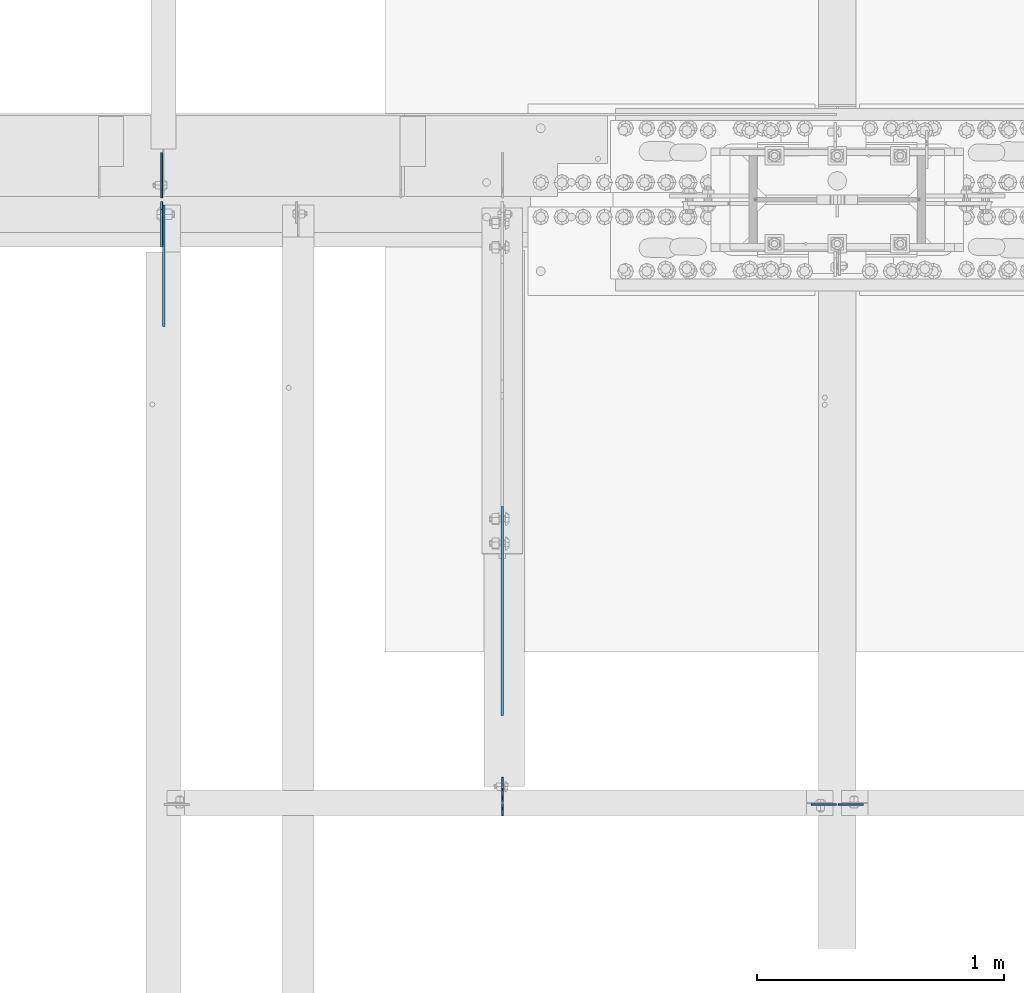
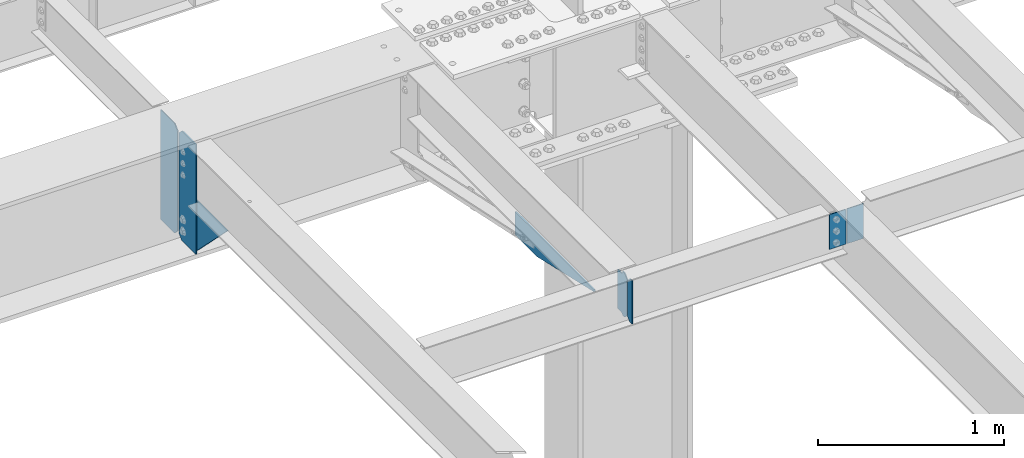
# One storey, part 1615 of 1763: 8 plates, 5 elements without a shape of their own.
"""IFC2X3 building model written with IfcOpenShell, lengths in millimetres."""

from ifc_helpers import new_model, si_unit, frame, origin_with_axes, place, context, subcontext, project, spatial, faceted_brep, material, type_object, element, aggregate, save


model = new_model("IFC2X3")

# Units and contexts
model_context = context("Model", 3, precision=1e-05, world=origin_with_axes())
body_context = subcontext(model_context, "Body", "Model", "MODEL_VIEW")
ifc_project = project(units=[si_unit("LENGTHUNIT", "METRE", prefix="MILLI"), si_unit("AREAUNIT", "SQUARE_METRE"), si_unit("VOLUMEUNIT", "CUBIC_METRE"), si_unit("MASSUNIT", "GRAM", prefix="KILO"), si_unit("TIMEUNIT", "SECOND"), si_unit("PLANEANGLEUNIT", "RADIAN"), si_unit("SOLIDANGLEUNIT", "STERADIAN"), si_unit("THERMODYNAMICTEMPERATUREUNIT", "DEGREE_CELSIUS"), si_unit("LUMINOUSINTENSITYUNIT", "LUMEN")], contexts=[model_context])

# Site, building, storey
site_placement = place(None, origin_with_axes())
site = spatial("IfcSite", under=ifc_project, at=site_placement, CompositionType="ELEMENT")
building_placement = place(site_placement, origin_with_axes())
building = spatial("IfcBuilding", under=site, at=building_placement, Name="Undefined", CompositionType="ELEMENT")
storey_placement = place(building_placement, origin_with_axes())
storey = spatial("IfcBuildingStorey", under=building, at=storey_placement, Name="Undefined", CompositionType="ELEMENT", Elevation=0.0)

# Assembly, plate
assembly_1_placement = place(storey_placement, origin_with_axes())
assembly_1 = element("IfcElementAssembly", 1, at=assembly_1_placement, inside=storey, Name="BEAM", AssemblyPlace="NOTDEFINED", PredefinedType="RIGID_FRAME")
ifc_material = material(Name="STEEL/A36")
plate_type_1 = type_object("IfcPlateType", PredefinedType="NOTDEFINED")
plate_1_placement = place(assembly_1_placement, frame((-62948.5747736983, 50880.5595338104, 4883.15), z_axis=(0.0, -1.0, 0.0), x_axis=(0.0, 0.0, -1.0)))
plate_1 = element("IfcPlate", 2, at=plate_1_placement, type_object=plate_type_1, material=ifc_material, Name="PLATE", context=body_context, shape_type="Brep", body=[
    faceted_brep([(0.0, -4.76249999999982, 0.0), (0.0, -4.76249999999709, 844.603210449219), (0.0, 4.76249999999709, 844.603210449219), (0.0, 4.76249999999982, 0.0), (12.6999998092651, -4.76249999999709, 844.603210449219), (12.6999998092651, 4.76249999999709, 844.603210449219), (152.399993896484, -4.76249999999709, 235.00325012207), (152.399993896484, 4.76249999999709, 235.00325012207), (152.400009155272, -4.76249999948777, 5.45696821063757e-12), (152.400009155273, 4.76250000051368, 3.63797880709171e-12)], [[[0, 1, 2, 3]], [[1, 4, 5, 2]], [[4, 6, 7, 5]], [[6, 8, 9, 7]], [[8, 0, 3, 9]], [[5, 7, 9, 3, 2]], [[8, 6, 4, 1, 0]]]),
])
aggregate(assembly_1, [plate_1])

assembly_2_placement = place(storey_placement, origin_with_axes())
assembly_2 = element("IfcElementAssembly", 3, at=assembly_2_placement, inside=storey, Name="BEAM", AssemblyPlace="NOTDEFINED", PredefinedType="RIGID_FRAME")
plate_type_2 = type_object("IfcPlateType", PredefinedType="NOTDEFINED")
plate_2_placement = place(assembly_2_placement, frame((-62946.987273746, 49684.78125, 4900.6125), z_axis=(0.0, 0.0, 1.0), x_axis=(0.0, 1.0, 0.0)))
plate_2 = element("IfcPlate", 4, at=plate_2_placement, type_object=plate_type_2, material=ifc_material, Name="PLATE", context=body_context, shape_type="Brep", body=[
    faceted_brep([(48.7345236062902, -3.17500000000291, 0.0), (48.7345236062902, 3.17500000000291, 0.0), (49.3854800386544, 3.17500000000291, 3.27257877585271), (49.3854800386544, -3.17500000000291, 3.27257877585271), (52.1384942519726, 3.17500000000291, 7.39275539271512), (52.1384942519726, -3.17500000000291, 7.39275539271512), (56.2586711318072, 3.17500000000291, 10.1457692124714), (56.2586711318072, -3.17500000000291, 10.1457692124714), (61.1187510223899, 3.17500000000291, 11.1124987868779), (61.1187510223899, -3.17500000000291, 11.1124987868779), (101.599998474121, -3.17500000000291, 11.1124949200548), (101.599998474121, 3.17500000000291, 11.1124949200548), (25.3999996184939, -3.17499999996653, 1.2732925824821e-11), (0.0, -3.17499999987194, 25.4000000001051), (0.0, 3.17500000014843, 25.4000000001197), (25.3999996185303, 3.17499995230901, 0.0), (0.0, -3.17500000000291, 261.937494277954), (0.0, 3.17500000000291, 261.937494277954), (25.3999996185303, -3.17500000000291, 287.337493896484), (25.3999996185303, 3.17500000000291, 287.337493896484), (48.4187500000044, -3.17500000000291, 287.337493896484), (48.4187500000044, 3.17500000000291, 287.337493896484), (48.4187500000044, -3.17500000000291, 280.987500572204), (48.4187500000044, 3.17500000000291, 280.987500572204), (49.3854799225956, -3.17500000000291, 276.127421054159), (49.3854799225956, 3.17500000000291, 276.127421054159), (52.1384938230694, -3.17500000000291, 272.007244586005), (52.1384938230694, 3.17500000000291, 272.007244586005), (56.2586702912231, -3.17500000000291, 269.254230685527), (56.2586702912231, 3.17500000000291, 269.254230685527), (61.1187498092695, -3.17500000000291, 268.287500762939), (61.1187498092695, 3.17500000000291, 268.287500762939), (101.599998474121, -3.17500000000291, 268.287500762939), (101.599998474121, 3.17500000000291, 268.287500762939)], [[[0, 1, 2, 3]], [[3, 2, 4, 5]], [[5, 4, 6, 7]], [[7, 6, 8, 9]], [[10, 9, 8, 11]], [[12, 13, 14, 15]], [[13, 16, 17, 14]], [[16, 18, 19, 17]], [[19, 18, 20, 21]], [[20, 22, 23, 21]], [[24, 25, 23, 22]], [[26, 27, 25, 24]], [[28, 29, 27, 26]], [[30, 31, 29, 28]], [[32, 33, 31, 30]], [[33, 32, 10, 11]], [[6, 4, 2, 1, 15, 14, 17, 19, 21, 23, 25, 27, 29, 31, 33, 11, 8]], [[12, 15, 1, 0]], [[32, 30, 28, 26, 24, 22, 20, 18, 16, 13, 12, 0, 3, 5, 7, 9, 10]]]),
])

# Assembly, plates
assembly_3_placement = place(storey_placement, origin_with_axes())
assembly_3 = element("IfcElementAssembly", 5, at=assembly_3_placement, inside=storey, Name="BEAM", AssemblyPlace="NOTDEFINED", PredefinedType="RIGID_FRAME")
plate_3_placement = place(assembly_3_placement, frame((-61598.4060236983, 49676.84375, 5156.2), z_axis=(-1.0, 0.0, 0.0), x_axis=(0.0, 0.0, -1.0)))
plate_3 = element("IfcPlate", 6, at=plate_3_placement, type_object=plate_type_2, material=ifc_material, Name="PLATE", context=body_context, shape_type="Brep", body=[
    faceted_brep([(1.81898940354586e-12, -3.17500000000291, 0.0), (0.0, -3.17499999999927, 101.599998474121), (0.0, 3.17499999999927, 101.599998474121), (-1.81898940354586e-12, 3.17499999997381, 0.0), (228.600006103516, -3.17499999999927, 101.599998474121), (228.600006103516, 3.17499999999927, 101.599998474121), (228.600006103516, -3.17500000001019, -7.27595761418343e-12), (228.600006103516, 3.17499999999563, -7.27595761418343e-12)], [[[0, 1, 2, 3]], [[1, 4, 5, 2]], [[4, 6, 7, 5]], [[6, 0, 3, 7]], [[5, 7, 3, 2]], [[6, 4, 1, 0]]]),
])
plate_4_placement = place(assembly_3_placement, frame((-61590.4685236983, 49676.84375, 5156.2), z_axis=(1.0, 0.0, 0.0), x_axis=(0.0, 0.0, -1.0)))
plate_4 = element("IfcPlate", 7, at=plate_4_placement, type_object=plate_type_2, material=ifc_material, Name="PLATE", context=body_context, shape_type="Brep", body=[
    faceted_brep([(1.81898940354586e-12, -3.17500000000291, 0.0), (0.0, -3.17499999999927, 101.599998474121), (0.0, 3.17499999999927, 101.599998474121), (-1.81898940354586e-12, 3.17499999997381, 0.0), (228.600006103516, -3.17499999999927, 101.599998474121), (228.600006103516, 3.17499999999927, 101.599998474121), (228.600006103516, -3.17500000001019, -7.27595761418343e-12), (228.600006103516, 3.17499999999563, -7.27595761418343e-12)], [[[0, 1, 2, 3]], [[1, 4, 5, 2]], [[4, 6, 7, 5]], [[6, 0, 3, 7]], [[5, 7, 3, 2]], [[6, 4, 1, 0]]]),
])
aggregate(assembly_3, [plate_3, plate_4])

assembly_4_placement = place(storey_placement, origin_with_axes())
assembly_4 = element("IfcElementAssembly", 8, at=assembly_4_placement, inside=storey, Name="BEAM", AssemblyPlace="NOTDEFINED", PredefinedType="RIGID_FRAME")
plate_type_3 = type_object("IfcPlateType", PredefinedType="NOTDEFINED")
plate_5_placement = place(assembly_4_placement, frame((-64324.9372737461, 52128.7375, 4448.175), z_axis=(0.0, 0.0, 1.0), x_axis=(0.0, 1.0, 0.0)))
plate_5 = element("IfcPlate", 9, at=plate_5_placement, type_object=plate_type_3, material=ifc_material, Name="PLATE", context=body_context, shape_type="Brep", body=[
    faceted_brep([(0.0, -3.17500000000291, 31.75), (0.0, -3.17500000000291, 687.387512207031), (0.0, 3.17500000000291, 687.387512207031), (0.0, 3.17500000000291, 31.75), (31.75, -3.17500000000291, 719.137512207031), (31.75, 3.17500000000291, 719.137512207031), (182.5625, -3.17500000000291, 719.137512207031), (182.5625, 3.17500000000291, 719.137512207031), (182.5625, -3.17500000000291, 0.0), (182.5625, 3.17500000000291, 0.0), (31.7499999999036, -3.17499999997381, 9.42916855706244e-11), (31.7499999998854, 3.17500000000291, 9.42916855706244e-11)], [[[0, 1, 2, 3]], [[1, 4, 5, 2]], [[4, 6, 7, 5]], [[6, 8, 9, 7]], [[8, 10, 11, 9]], [[10, 0, 3, 11]], [[5, 7, 9, 11, 3, 2]], [[10, 8, 6, 4, 1, 0]]]),
])
plate_type_4 = type_object("IfcPlateType", PredefinedType="NOTDEFINED")
plate_6_placement = place(assembly_4_placement, frame((-64325.7320237632, 52112.8625, 4448.175), z_axis=(0.0, 0.0, 1.0), x_axis=(0.0, -1.0, 0.0)))
plate_6 = element("IfcPlate", 10, at=plate_6_placement, type_object=plate_type_4, material=ifc_material, Name="PLATE", context=body_context, shape_type="Brep", body=[
    faceted_brep([(0.0, -3.96899999999732, 31.75), (0.0, -3.96899999999732, 687.387512207031), (0.0, 3.96899999999732, 687.387512207031), (0.0, 3.96899999999732, 31.75), (31.75, -3.96899999999732, 719.137512207031), (31.75, 3.96899999999732, 719.137512207031), (182.5625, -3.96899999999732, 719.137512207031), (182.5625, 3.96899999999732, 719.137512207031), (182.5625, -3.96899999999732, 0.0), (182.5625, 3.96899999999732, 0.0), (31.75, -3.96899999999732, 0.0), (31.75, 3.96899999999732, 0.0)], [[[0, 1, 2, 3]], [[1, 4, 5, 2]], [[4, 6, 7, 5]], [[6, 8, 9, 7]], [[8, 10, 11, 9]], [[10, 0, 3, 11]], [[5, 7, 9, 11, 3, 2]], [[10, 8, 6, 4, 1, 0]]]),
])
aggregate(assembly_4, [plate_5, plate_6])

# Assembly, plate
assembly_5_placement = place(storey_placement, origin_with_axes())
assembly_5 = element("IfcElementAssembly", 11, at=assembly_5_placement, inside=storey, Name="BEAM", AssemblyPlace="NOTDEFINED", PredefinedType="RIGID_FRAME")
plate_type_5 = type_object("IfcPlateType", PredefinedType="NOTDEFINED")
plate_7_placement = place(assembly_5_placement, frame((-64316.999773746, 51930.3004272461, 4794.2499684514), z_axis=(0.0, 0.0, -1.0), x_axis=(0.0, -1.0, 0.0)))
plate_7 = element("IfcPlate", 12, at=plate_7_placement, type_object=plate_type_5, material=ifc_material, Name="PLATE", context=body_context, shape_type="Brep", body=[
    faceted_brep([(0.0, -4.76249999999982, 0.0), (-169.862075805664, -4.76249999999709, 6.30279828328639e-10), (-169.862075805664, 4.76249999999709, 6.30279828328639e-10), (0.0, 4.76249999999982, 0.0), (-169.862091064453, -4.76249999999709, 323.002471923828), (-169.862091064453, 4.76249999999709, 323.002471923828), (6.38101482763886e-09, -4.76249999999709, 323.002471923828), (6.38101482763886e-09, 4.76249999999709, 323.002471923828), (322.262145996094, -4.76249999999709, -1.15778675535694e-09), (322.262145996094, 4.76249999999709, -1.15778675535694e-09)], [[[0, 1, 2, 3]], [[1, 4, 5, 2]], [[4, 6, 7, 5]], [[6, 8, 9, 7]], [[8, 0, 3, 9]], [[5, 7, 9, 3, 2]], [[8, 6, 4, 1, 0]]]),
])
aggregate(assembly_5, [plate_7])

# Plate
plate_type_6 = type_object("IfcPlateType", PredefinedType="NOTDEFINED")
plate_8_placement = place(assembly_2_placement, frame((-62946.987273746, 49680.01875, 4900.6125), z_axis=(0.0, 0.0, 1.0), x_axis=(0.0, -1.0, 0.0)))
plate_8 = element("IfcPlate", 13, at=plate_8_placement, type_object=plate_type_6, material=ifc_material, Name="PLATE", context=body_context, shape_type="Brep", body=[
    faceted_brep([(0.0, -3.17499999987194, 25.4000000001051), (0.0, -3.17500000000291, 260.35000038147), (0.0, 3.17500000000291, 260.35000038147), (0.0, 3.17500000014843, 25.4000000001197), (25.3999996185303, -3.17500000000291, 285.75), (25.3999996185303, 3.17500000000291, 285.75), (48.4187507629395, -3.17500000000291, 285.75), (48.4187507629395, 3.17500000000291, 285.75), (48.4187507629395, -3.17500000000291, 0.0), (48.4187507629395, 3.17500000000291, 0.0), (25.3999996184939, -3.17499999996653, 1.2732925824821e-11), (25.3999996185303, 3.17499995230901, 0.0)], [[[0, 1, 2, 3]], [[1, 4, 5, 2]], [[4, 6, 7, 5]], [[6, 8, 9, 7]], [[8, 10, 11, 9]], [[10, 0, 3, 11]], [[5, 7, 9, 11, 3, 2]], [[10, 8, 6, 4, 1, 0]]]),
])

aggregate(assembly_2, [plate_8, plate_2])

save(model, "model.ifc")
